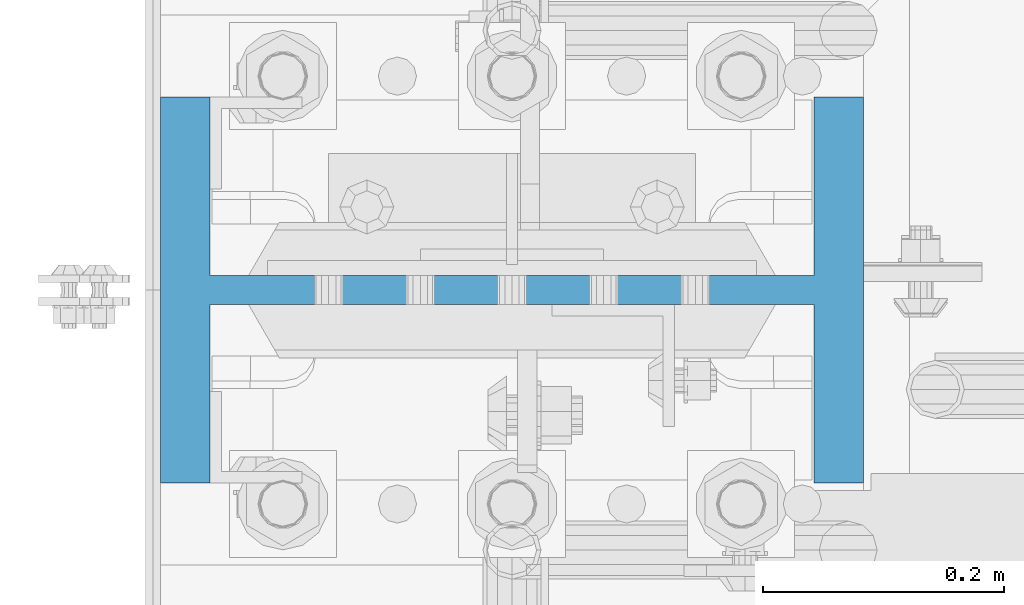
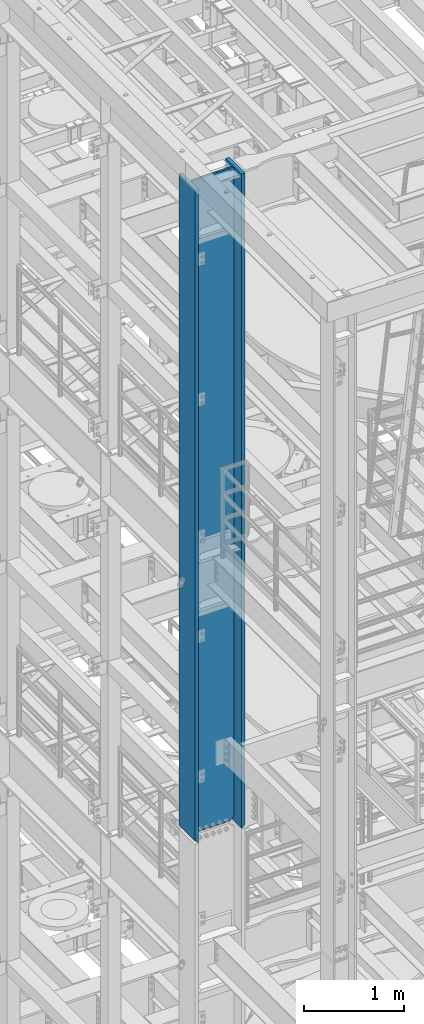
# One storey, part 597 of 1876: 1 column, 1 element without a shape of its own.
"""IFC2X3 building model written with IfcOpenShell, lengths in millimetres."""

from ifc_helpers import new_model, si_unit, frame, origin_with_axes, place, context, subcontext, project, spatial, faceted_brep, material, type_object, element, aggregate, save


model = new_model("IFC2X3")

# Units and contexts
model_context = context("Model", 3, precision=1e-05, world=origin_with_axes())
body_context = subcontext(model_context, "Body", "Model", "MODEL_VIEW")
ifc_project = project(units=[si_unit("LENGTHUNIT", "METRE", prefix="MILLI"), si_unit("AREAUNIT", "SQUARE_METRE"), si_unit("VOLUMEUNIT", "CUBIC_METRE"), si_unit("MASSUNIT", "GRAM", prefix="KILO"), si_unit("TIMEUNIT", "SECOND"), si_unit("PLANEANGLEUNIT", "RADIAN"), si_unit("SOLIDANGLEUNIT", "STERADIAN"), si_unit("THERMODYNAMICTEMPERATUREUNIT", "DEGREE_CELSIUS"), si_unit("LUMINOUSINTENSITYUNIT", "LUMEN")], contexts=[model_context])

# Site, building, storey
site_placement = place(None, origin_with_axes())
site = spatial("IfcSite", under=ifc_project, at=site_placement, CompositionType="ELEMENT")
building_placement = place(site_placement, origin_with_axes())
building = spatial("IfcBuilding", under=site, at=building_placement, Name="Undefined", CompositionType="ELEMENT")
storey_placement = place(building_placement, origin_with_axes())
storey = spatial("IfcBuildingStorey", under=building, at=storey_placement, Name="Undefined", CompositionType="ELEMENT", Elevation=0.0)

# Assembly, column
assembly_placement = place(storey_placement, origin_with_axes())
assembly = element("IfcElementAssembly", 1, at=assembly_placement, inside=storey, Name="COLUMN", AssemblyPlace="NOTDEFINED", PredefinedType="RIGID_FRAME")
ifc_material = material(Name="STEEL/A992")
column_type = type_object("IfcColumnType", Name="W21X201", PredefinedType="NOTDEFINED")
column_placement = place(assembly_placement, frame((0.0, -4572.0, 14528.8), z_axis=(-1.0, 0.0, 0.0), x_axis=(0.0, 0.0, 1.0)))
column = element("IfcColumn", 2, at=column_placement, type_object=column_type, material=ifc_material, Name="COLUMN", ObjectType="W21X201", context=body_context, shape_type="Brep", body=[
    faceted_brep([(26.9875007629398, -11.9062500000018, 204.691852352942), (25.7903180721823, -10.7090673092443, 203.891920453292), (6.35000000000036, 8.73125076293763, 200.02500076294), (6.35000000000036, 8.73125076293763, -200.02500076294), (25.7903188351211, -10.7090680721831, -203.891920453292), (26.9875007629398, -11.90625, -204.691851843163), (42.2710247077357, -11.90625, -214.903976055204), (42.2710247077357, 11.90625, -214.903976055204), (53.2830803096476, 11.90625, -231.384681927818), (53.2830803096476, -11.90625, -231.384681927818), (8026.4, -160.3375, 292.1), (8026.4, 160.3375, 292.1), (44.4500000000007, 160.3375, 292.1), (44.4500000000007, -160.3375, 292.1), (6.35000000000036, -160.3375, 250.825), (57.1499992370609, -160.3375, 250.825), (8026.4, -160.3375, 250.825), (6.35000000000036, -160.3375, 254.0), (6.35000000000036, -11.90625, 250.825), (6.35000000000036, 160.3375, 254.0), (6.35000000000036, 160.3375, 250.825), (6.35000000000036, 11.90625, 250.825), (6.35000000000036, 8.73125076293763, 250.825), (8026.4, 160.3375, 250.825), (57.1499992370609, 160.3375, 250.825), (57.1499992370609, 11.90625, 250.825), (8026.4, 11.90625, 250.825), (57.1499992370609, -11.90625, 250.825000000001), (53.2830795467089, 11.90625, 231.384681927818), (53.2830795467089, -11.90625, 231.384681927818), (26.9875007629398, -11.90625, 250.825), (8026.4, -11.90625, 250.825), (57.1499999999996, 160.3375, -250.825), (6.35000000000036, 160.3375, -250.825), (6.35000000000036, 11.90625, -250.825), (57.1499999999996, 11.90625, -250.825), (8026.4, 11.90625, -250.825), (8026.4, 160.3375, -250.825), (8026.4, 160.3375, -292.1), (8026.4, -160.3375, -292.1), (44.4500000000007, -160.3375, -292.1), (44.4500000000007, 160.3375, -292.1), (8026.4, -160.3375, -250.825), (57.1499999999996, -160.3375, -250.825), (6.35000000000036, -160.3375, -250.825), (6.35000000000036, -160.3375, -254.000000000001), (6.35000000000036, 160.3375, -254.000000000001), (8026.4, -11.90625, -250.825), (57.1499999999996, -11.90625, -250.825000000001), (26.9875007629398, -11.90625, -250.825), (6.35000000000036, -11.90625, -250.825), (6.35000000000036, 8.73125076293763, -250.825), (25.7903188351211, 11.90625, -203.891920453292), (6.35000000000036, 11.90625, -200.02500076294), (6.35000000000036, 11.90625, 200.02500076294), (25.7903180721823, 11.90625, 203.891920453292), (42.271023944797, 11.90625, 214.903976055204), (42.271023944797, -11.90625, 214.903976055204)], [[[0, 1, 2, 3, 4, 5]], [[6, 7, 8, 9]], [[10, 11, 12, 13]], [[14, 15, 16, 10, 13, 17]], [[18, 14, 17, 19, 20, 21, 22]], [[13, 12, 19, 17]], [[11, 23, 24, 20, 19, 12]], [[25, 21, 20, 24, 23, 26]], [[27, 25, 28, 29]], [[30, 18, 22, 21, 25, 27]], [[15, 14, 18, 30, 27, 31, 16]], [[32, 33, 34, 35, 36, 37]], [[38, 39, 40, 41]], [[39, 42, 43, 44, 45, 40]], [[40, 45, 46, 41]], [[33, 32, 37, 38, 41, 46]], [[36, 26, 23, 11, 10, 16, 31, 47, 42, 39, 38, 37]], [[48, 49, 50, 44, 43, 42, 47]], [[34, 33, 46, 45, 44, 50, 51]], [[49, 48, 35, 34, 51, 50]], [[9, 8, 35, 48]], [[7, 52, 53, 54, 55, 56, 28, 25, 26, 36, 35, 8]], [[29, 28, 56, 57]], [[6, 9, 48, 47, 31, 27, 29, 57, 0, 5]], [[52, 7, 6, 5, 4]], [[53, 52, 4, 3]], [[54, 53, 3, 2]], [[55, 54, 2, 1]], [[57, 56, 55, 1, 0]]]),
])
aggregate(assembly, [column])

save(model, "model.ifc")
